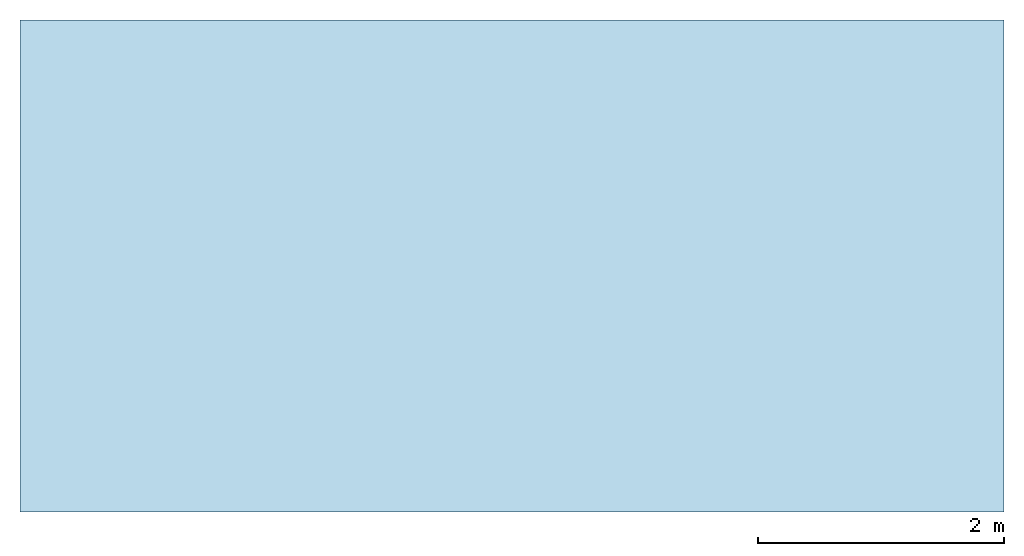
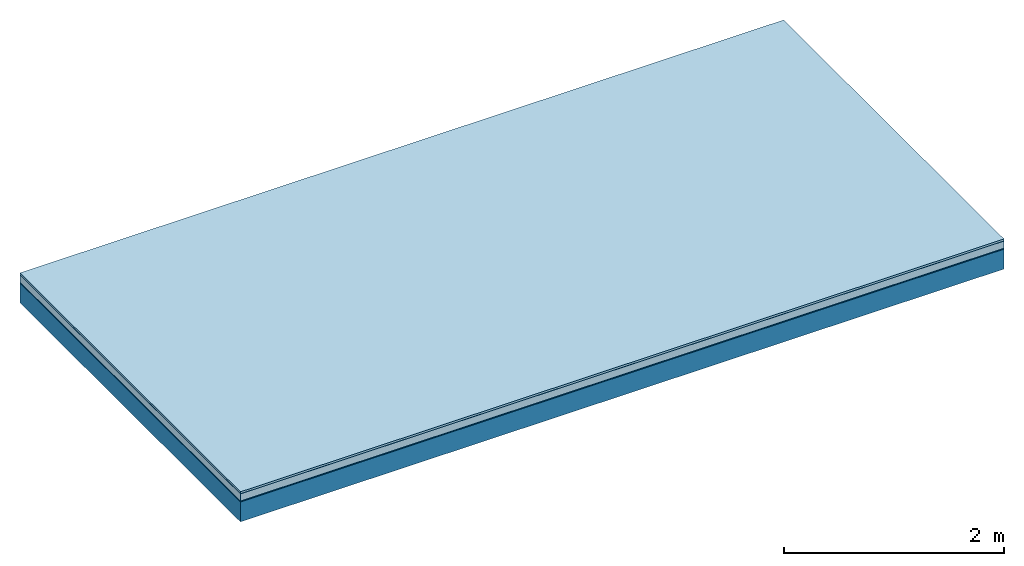
# One storey: 5 plates, 1 member, 1 element without a shape of its own.
"""IFC4 building model written with IfcOpenShell, lengths in metres."""

from ifc_helpers import new_model, si_unit, derived_unit, direction, frame, frame_2d, origin, origin_with_axes, place, context, project, spatial, rectangle, extrude, material, layer, layer_set, type_object, element, aggregate, save


model = new_model("IFC4")

# Units and contexts
plan_context = context("Plan", 3, precision=1e-05, world=origin(), true_north=direction((0.0, 1.0)))
model_context = context("Model", 3, precision=1e-05, world=origin(), true_north=direction((0.0, 1.0)))
ifc_project = project(units=[si_unit("LENGTHUNIT", "METRE"), derived_unit("SOUNDPRESSUREUNIT", [(si_unit("PRESSUREUNIT", "PASCAL", prefix="MICRO"), 0)]), si_unit("ENERGYUNIT", "JOULE", prefix="MEGA"), si_unit("MASSUNIT", "GRAM", prefix="KILO"), derived_unit("THERMALTRANSMITTANCEUNIT", [(si_unit("POWERUNIT", "WATT"), 1), (si_unit("AREAUNIT", "SQUARE_METRE"), -1), (si_unit("THERMODYNAMICTEMPERATUREUNIT", "KELVIN"), -1)]), derived_unit("AREADENSITYUNIT", [(si_unit("MASSUNIT", "GRAM", prefix="KILO"), 1), (si_unit("AREAUNIT", "SQUARE_METRE"), -1)]), derived_unit("USERDEFINED", [(si_unit("ENERGYUNIT", "JOULE", prefix="MEGA"), 1), (si_unit("AREAUNIT", "SQUARE_METRE"), -1)])], contexts=[plan_context, model_context])

# Site, building, storey
site = spatial("IfcSite", under=ifc_project)
building_placement = place(None, origin())
building = spatial("IfcBuilding", under=site, at=building_placement)
storey_placement = place(building_placement, origin())
storey = spatial("IfcBuildingStorey", under=building, at=storey_placement)

# Slab, member, plates
ifc_material_1 = material(Name="with tongue and groove", Category="07.009")
ifc_layer_1 = layer(ifc_material_1, 0.022, Name="Flooring")
ifc_material_2 = material(Category="09.006")
ifc_layer_2 = layer(ifc_material_2, 0.0005, Name="layer")
ifc_material_3 = material(Category="07.011")
ifc_layer_3 = layer(ifc_material_3, 0.08, Name="On-material")
ifc_material_4 = material(Name="Wood fiber generic product", Category="10.009")
ifc_layer_4 = layer(ifc_material_4, 0.01, Name="Impact sound insulation")
ifc_material_5 = material(Name="protection", Category="09.007")
ifc_layer_5 = layer(ifc_material_5, 0.0005, Name="Sub-floor")
ifc_material_6 = material(Name="no composite action")
ifc_layer_6 = layer(ifc_material_6, 0.0, Name="Bond")
ifc_layer_7 = layer(None, 0.22, Name="Supporting structure")
ifc_layer_set = layer_set([ifc_layer_1, ifc_layer_2, ifc_layer_3, ifc_layer_4, ifc_layer_5, ifc_layer_6, ifc_layer_7])
slab_type = type_object("IfcSlabType", Name="A2020", PredefinedType="NOTDEFINED", material=ifc_layer_set)
slab_placement = place(None, frame((0.0, 0.0, 0.0), z_axis=(0.0, 0.0, -1.0), x_axis=(1.0, 0.0, 0.0)))
slab = element("IfcSlab", 1, at=slab_placement, inside=storey, type_object=slab_type, material=ifc_layer_set, Name="Slab #1")
ifc_material_7 = material(Name="Solid timber panel")
member_placement = place(slab_placement, origin())
member = element("IfcMember", 2, at=member_placement, material=ifc_material_7, Name="Supporting structure", context=plan_context, shape_type="SweptSolid", body=[
    extrude(rectangle(XDim=1.0, YDim=0.22, at=frame_2d((0.5, 0.11), x_axis=(1.0, 0.0))), frame((0.0, 4.0, 0.113), z_axis=(0.0, -1.0, 0.0), x_axis=(1.0, 0.0, 0.0)), (0.0, 0.0, 1.0), 4.0),
    extrude(rectangle(XDim=1.0, YDim=0.22, at=frame_2d((0.5, 0.11), x_axis=(1.0, 0.0))), frame((1.0, 4.0, 0.113), z_axis=(0.0, -1.0, 0.0), x_axis=(1.0, 0.0, 0.0)), (0.0, 0.0, 1.0), 4.0),
    extrude(rectangle(XDim=1.0, YDim=0.22, at=frame_2d((0.5, 0.11), x_axis=(1.0, 0.0))), frame((2.0, 4.0, 0.113), z_axis=(0.0, -1.0, 0.0), x_axis=(1.0, 0.0, 0.0)), (0.0, 0.0, 1.0), 4.0),
    extrude(rectangle(XDim=1.0, YDim=0.22, at=frame_2d((0.5, 0.11), x_axis=(1.0, 0.0))), frame((3.0, 4.0, 0.113), z_axis=(0.0, -1.0, 0.0), x_axis=(1.0, 0.0, 0.0)), (0.0, 0.0, 1.0), 4.0),
    extrude(rectangle(XDim=1.0, YDim=0.22, at=frame_2d((0.5, 0.11), x_axis=(1.0, 0.0))), frame((4.0, 4.0, 0.113), z_axis=(0.0, -1.0, 0.0), x_axis=(1.0, 0.0, 0.0)), (0.0, 0.0, 1.0), 4.0),
    extrude(rectangle(XDim=1.0, YDim=0.22, at=frame_2d((0.5, 0.11), x_axis=(1.0, 0.0))), frame((5.0, 4.0, 0.113), z_axis=(0.0, -1.0, 0.0), x_axis=(1.0, 0.0, 0.0)), (0.0, 0.0, 1.0), 4.0),
    extrude(rectangle(XDim=1.0, YDim=0.22, at=frame_2d((0.5, 0.11), x_axis=(1.0, 0.0))), frame((6.0, 4.0, 0.113), z_axis=(0.0, -1.0, 0.0), x_axis=(1.0, 0.0, 0.0)), (0.0, 0.0, 1.0), 4.0),
    extrude(rectangle(XDim=1.0, YDim=0.22, at=frame_2d((0.5, 0.11), x_axis=(1.0, 0.0))), frame((7.0, 4.0, 0.113), z_axis=(0.0, -1.0, 0.0), x_axis=(1.0, 0.0, 0.0)), (0.0, 0.0, 1.0), 4.0),
])
plate_1_placement = place(slab_placement, origin())
plate_1 = element("IfcPlate", 3, at=plate_1_placement, material=ifc_material_1, Name="Flooring", context=plan_context, shape_type="SweptSolid", body=[
    extrude(rectangle(XDim=8.0, YDim=4.0, at=frame_2d((4.0, 2.0), x_axis=(1.0, 0.0))), origin_with_axes(), (0.0, 0.0, 1.0), 0.022),
])
plate_2_placement = place(slab_placement, origin())
plate_2 = element("IfcPlate", 4, at=plate_2_placement, material=ifc_material_2, Name="layer", context=plan_context, shape_type="SweptSolid", body=[
    extrude(rectangle(XDim=8.0, YDim=4.0, at=frame_2d((4.0, 2.0), x_axis=(1.0, 0.0))), frame((0.0, 0.0, 0.022), z_axis=(0.0, 0.0, 1.0), x_axis=(1.0, 0.0, 0.0)), (0.0, 0.0, 1.0), 0.0005),
])
plate_3_placement = place(slab_placement, origin())
plate_3 = element("IfcPlate", 5, at=plate_3_placement, material=ifc_material_3, Name="On-material", context=plan_context, shape_type="SweptSolid", body=[
    extrude(rectangle(XDim=8.0, YDim=4.0, at=frame_2d((4.0, 2.0), x_axis=(1.0, 0.0))), frame((0.0, 0.0, 0.0225), z_axis=(0.0, 0.0, 1.0), x_axis=(1.0, 0.0, 0.0)), (0.0, 0.0, 1.0), 0.08),
])
plate_4_placement = place(slab_placement, origin())
plate_4 = element("IfcPlate", 6, at=plate_4_placement, material=ifc_material_4, Name="Impact sound insulation", context=plan_context, shape_type="SweptSolid", body=[
    extrude(rectangle(XDim=8.0, YDim=4.0, at=frame_2d((4.0, 2.0), x_axis=(1.0, 0.0))), frame((0.0, 0.0, 0.1025), z_axis=(0.0, 0.0, 1.0), x_axis=(1.0, 0.0, 0.0)), (0.0, 0.0, 1.0), 0.01),
])
plate_5_placement = place(slab_placement, origin())
plate_5 = element("IfcPlate", 7, at=plate_5_placement, material=ifc_material_5, Name="Sub-floor", context=plan_context, shape_type="SweptSolid", body=[
    extrude(rectangle(XDim=8.0, YDim=4.0, at=frame_2d((4.0, 2.0), x_axis=(1.0, 0.0))), frame((0.0, 0.0, 0.1125), z_axis=(0.0, 0.0, 1.0), x_axis=(1.0, 0.0, 0.0)), (0.0, 0.0, 1.0), 0.0005),
])
aggregate(slab, [plate_1, plate_2, plate_3, plate_4, plate_5, member])

save(model, "model.ifc")
